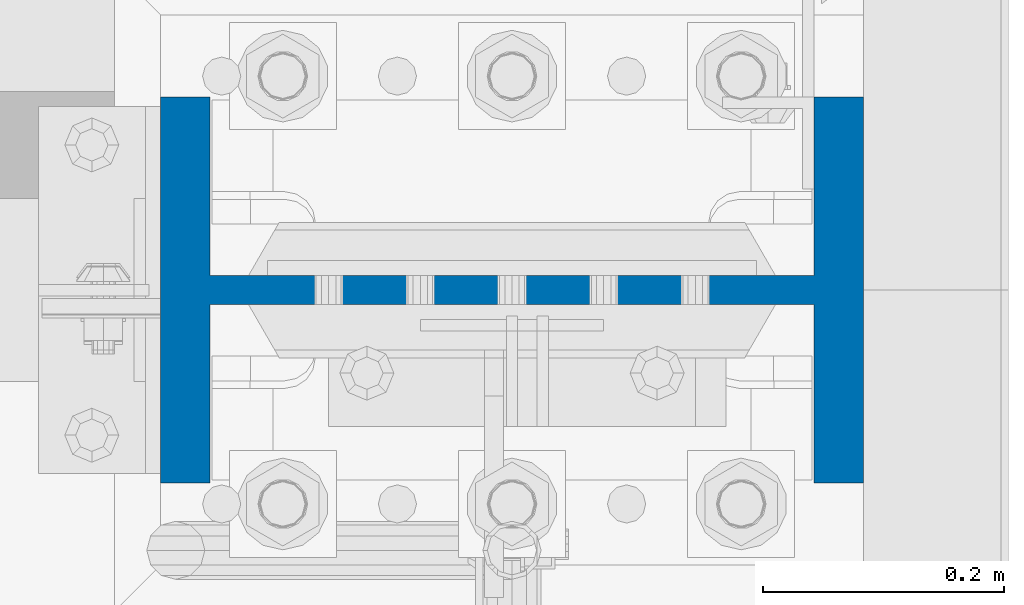
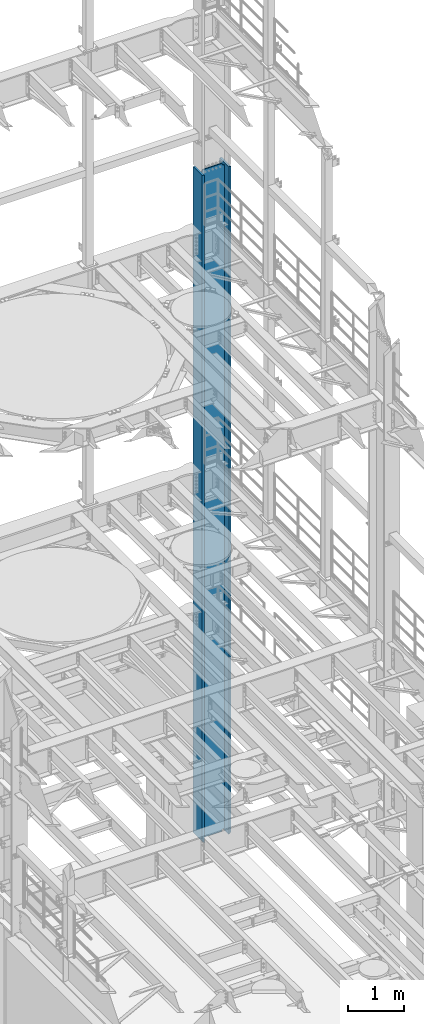
# One storey, part 775 of 1876: 1 column, 1 element without a shape of its own.
"""IFC2X3 building model written with IfcOpenShell, lengths in millimetres."""

import ifcopenshell
import ifcopenshell.guid

model = None  # the IFC model being written
_history = None  # IfcOwnerHistory: only IFC2X3 demands one
_inside = {}  # id of a spatial element -> (the spatial element, [elements in it])
_under = {}  # id of a project, library or spatial element -> (it, [spatial elements below it])
_declared = {}  # id of a project -> (the project, [libraries it declares])
_typed = {}  # id of a type object -> (the type object, [elements of that type])
_made_of = {}  # id of a material, layer set ... -> (it, [elements and type objects made of it])


def new_model(schema):
    """Start an empty IFC model of exactly this schema.

    Asked for "IFC4X3", IfcOpenShell would pick the latest addendum, in which some entities
    have other attributes; the version numbers below select the first issue.
    IFC2X3 requires an IfcOwnerHistory on every rooted entity: one is made here for all.
    """
    global model, _history
    if schema == "IFC4X3":
        model = ifcopenshell.file(schema_version=(4, 3, 0, 0))
    else:
        model = ifcopenshell.file(schema=schema)
    _inside.clear()
    _under.clear()
    _declared.clear()
    _typed.clear()
    _made_of.clear()
    _history = None
    if model.schema == "IFC2X3":
        org = make("IfcOrganization", Name="unknown")
        user = make(
            "IfcPersonAndOrganization",
            ThePerson=make("IfcPerson", FamilyName="unknown"),
            TheOrganization=org,
        )
        app = make(
            "IfcApplication",
            ApplicationDeveloper=org,
            Version="unknown",
            ApplicationFullName="unknown",
            ApplicationIdentifier="unknown",
        )
        _history = make(
            "IfcOwnerHistory",
            OwningUser=user,
            OwningApplication=app,
            ChangeAction="ADDED",
            CreationDate=0,
        )
    return model


def make(cls, **values):
    """One entity of the class cls with the attributes given. An attribute that is None is left unset."""
    return model.create_entity(
        cls, **{name: value for name, value in values.items() if value is not None}
    )


def rooted(cls, **values):
    """An entity with a GlobalId (a new one), such as an element, a storey or a relation."""
    return make(cls, GlobalId=ifcopenshell.guid.new(), OwnerHistory=_history, **values)


def si_unit(unit_type, name, prefix=None):
    """IfcSIUnit, for example si_unit("LENGTHUNIT", "METRE", prefix="MILLI")."""
    return make("IfcSIUnit", UnitType=unit_type, Prefix=prefix, Name=name)


def assignment(units):
    """IfcUnitAssignment: the units of a project."""
    return None if units is None else make("IfcUnitAssignment", Units=units)


def point(xyz):
    """IfcCartesianPoint."""
    return None if xyz is None else make("IfcCartesianPoint", Coordinates=xyz)


def direction(xyz):
    """IfcDirection."""
    return None if xyz is None else make("IfcDirection", DirectionRatios=xyz)


def frame(location, z_axis=None, x_axis=None):
    """IfcAxis2Placement3D, a coordinate frame: its origin and axes. An axis left out is left unset."""
    return make(
        "IfcAxis2Placement3D",
        Location=point(location),
        Axis=direction(z_axis),
        RefDirection=direction(x_axis),
    )


def origin_with_axes():
    """The frame at (0, 0, 0) with the z axis (0, 0, 1) and the x axis (1, 0, 0) written out."""
    return frame((0.0, 0.0, 0.0), z_axis=(0.0, 0.0, 1.0), x_axis=(1.0, 0.0, 0.0))


def place(relative_to, where):
    """IfcLocalPlacement: puts the frame where relative to a parent placement (None: the world)."""
    return make(
        "IfcLocalPlacement", PlacementRelTo=relative_to, RelativePlacement=where
    )


def context(
    kind, dimensions, precision=None, world=None, true_north=None, identifier=None
):
    """IfcGeometricRepresentationContext, for example the 3D "Model" context."""
    return make(
        "IfcGeometricRepresentationContext",
        ContextIdentifier=identifier,
        ContextType=kind,
        CoordinateSpaceDimension=dimensions,
        Precision=precision,
        WorldCoordinateSystem=world,
        TrueNorth=true_north,
    )


def subcontext(parent, identifier, kind, view, scale=None):
    """IfcGeometricRepresentationSubContext, for example "Body" below "Model"."""
    return make(
        "IfcGeometricRepresentationSubContext",
        ContextIdentifier=identifier,
        ContextType=kind,
        ParentContext=parent,
        TargetScale=scale,
        TargetView=view,
    )


def project(units=None, contexts=None):
    """IfcProject with its units and contexts."""
    return rooted(
        "IfcProject",
        Name="project",
        RepresentationContexts=contexts,
        UnitsInContext=assignment(units),
    )


def spatial(cls, under=None, at=None, **own):
    """A site, building, storey or space (cls), placed at a placement, below another one or the project."""
    s = rooted(cls, ObjectPlacement=at, **own)
    if under is not None:
        _under.setdefault(under.id(), (under, []))[1].append(s)
    return s


def faces_of(points, faces, orient=None, outer=None):
    """IfcFace entities. A face is a list of loops; a loop is a list of indices into points, from 0.

    orient and outer hold one flag for each loop. By default every Orientation is true, the
    first loop of a face is its IfcFaceOuterBound and the others are IfcFaceBound.
    """
    made = []
    for i, loops in enumerate(faces):
        bounds = []
        for j, loop in enumerate(loops):
            is_outer = j == 0 if outer is None else outer[i][j]
            bounds.append(
                make(
                    "IfcFaceOuterBound" if is_outer else "IfcFaceBound",
                    Bound=make("IfcPolyLoop", Polygon=[points[k] for k in loop]),
                    Orientation=True if orient is None else orient[i][j],
                )
            )
        made.append(make("IfcFace", Bounds=bounds))
    return made


def faceted_brep(points, faces, orient=None, outer=None, voids=None):
    """IfcFacetedBrep: a solid bounded by flat faces; with voids (closed shells), ...WithVoids."""
    shared = [point(p) for p in points]
    hull = make("IfcClosedShell", CfsFaces=faces_of(shared, faces, orient, outer))
    if voids is None:
        return make("IfcFacetedBrep", Outer=hull)
    return make(
        "IfcFacetedBrepWithVoids",
        Outer=hull,
        Voids=[
            make(cls, CfsFaces=faces_of(shared, fs, o, b)) for cls, fs, o, b in voids
        ],
    )


def shape(context_of_items, identifier, shape_type, items):
    """IfcShapeRepresentation: the items that make up one representation, for example the "Body"."""
    return make(
        "IfcShapeRepresentation",
        ContextOfItems=context_of_items,
        RepresentationIdentifier=identifier,
        RepresentationType=shape_type,
        Items=items,
    )


def material(Name=None, Category=None):
    """IfcMaterial."""
    return make("IfcMaterial", Name=Name, Category=Category)


def made_of(thing, what):
    """Note that an element or type object is made of a material, layer set ...; save() writes the relation."""
    if what is not None:
        _made_of.setdefault(what.id(), (what, []))[1].append(thing)
    return thing


def type_object(cls, material=None, **own):
    """A type object (cls), such as IfcWallType, which elements share."""
    return made_of(rooted(cls, **own), material)


def element(
    cls,
    number,
    at=None,
    inside=None,
    cuts=None,
    type_object=None,
    material=None,
    context=None,
    identifier="Body",
    shape_type=None,
    held_by="IfcProductDefinitionShape",
    body=None,
    shapes=None,
    **own,
):
    """One element of the class cls, such as IfcWall. Its Tag is "e" and its number.

    at: its placement. inside: the storey or other place that contains it. cuts: it is an
    opening in that element (IfcRelVoidsElement). A single representation is given by context,
    identifier, shape_type and body (its items); several are given by shapes. held_by: the class
    of the entity that holds the representations. save() writes the other relations.
    """
    e = rooted(cls, Tag="e%d" % number, ObjectPlacement=at, **own)
    if body is not None:
        shapes = [shape(context, identifier, shape_type, body)]
    if shapes is not None:
        e.Representation = make(held_by, Representations=shapes)
    if inside is not None:
        _inside.setdefault(inside.id(), (inside, []))[1].append(e)
    if cuts is not None:
        rooted(
            "IfcRelVoidsElement", RelatingBuildingElement=cuts, RelatedOpeningElement=e
        )
    if type_object is not None:
        _typed.setdefault(type_object.id(), (type_object, []))[1].append(e)
    return made_of(e, material)


def aggregate(whole, parts):
    """IfcRelAggregates: a whole, such as a stair, and the parts it consists of."""
    return rooted("IfcRelAggregates", RelatingObject=whole, RelatedObjects=parts)


def save(model, path):
    """Write the relations noted so far, then the file.

    IfcRelAggregates (storeys below a building ...), IfcRelContainedInSpatialStructure (elements
    in a storey), IfcRelDefinesByType, IfcRelAssociatesMaterial and IfcRelDeclares: one each for
    every whole, place, type object, material and project.
    """
    for whole, parts in _under.values():
        aggregate(whole, parts)
    for where, things in _inside.values():
        rooted(
            "IfcRelContainedInSpatialStructure",
            RelatedElements=things,
            RelatingStructure=where,
        )
    for kind, things in _typed.values():
        rooted("IfcRelDefinesByType", RelatedObjects=things, RelatingType=kind)
    for what, things in _made_of.values():
        rooted("IfcRelAssociatesMaterial", RelatedObjects=things, RelatingMaterial=what)
    for by, libraries in _declared.values():
        rooted("IfcRelDeclares", RelatingContext=by, RelatedDefinitions=libraries)
    model.write(path)


model = new_model("IFC2X3")

# Units and contexts
model_context = context("Model", 3, precision=1e-05, world=origin_with_axes())
body_context = subcontext(model_context, "Body", "Model", "MODEL_VIEW")
ifc_project = project(units=[si_unit("LENGTHUNIT", "METRE", prefix="MILLI"), si_unit("AREAUNIT", "SQUARE_METRE"), si_unit("VOLUMEUNIT", "CUBIC_METRE"), si_unit("MASSUNIT", "GRAM", prefix="KILO"), si_unit("TIMEUNIT", "SECOND"), si_unit("PLANEANGLEUNIT", "RADIAN"), si_unit("SOLIDANGLEUNIT", "STERADIAN"), si_unit("THERMODYNAMICTEMPERATUREUNIT", "DEGREE_CELSIUS"), si_unit("LUMINOUSINTENSITYUNIT", "LUMEN")], contexts=[model_context])

# Site, building, storey
site_placement = place(None, origin_with_axes())
site = spatial("IfcSite", under=ifc_project, at=site_placement, CompositionType="ELEMENT")
building_placement = place(site_placement, origin_with_axes())
building = spatial("IfcBuilding", under=site, at=building_placement, Name="Undefined", CompositionType="ELEMENT")
storey_placement = place(building_placement, origin_with_axes())
storey = spatial("IfcBuildingStorey", under=building, at=storey_placement, Name="Undefined", CompositionType="ELEMENT", Elevation=0.0)

# Assembly, column
assembly_placement = place(storey_placement, origin_with_axes())
assembly = element("IfcElementAssembly", 1, at=assembly_placement, inside=storey, Name="COLUMN", AssemblyPlace="NOTDEFINED", PredefinedType="RIGID_FRAME")
ifc_material = material(Name="STEEL/A992")
column_type = type_object("IfcColumnType", Name="W21X201", PredefinedType="NOTDEFINED")
column_placement = place(assembly_placement, frame((7620.0, 13716.0, 0.0), z_axis=(-1.0, 0.0, 0.0), x_axis=(0.0, 0.0, 1.0)))
column = element("IfcColumn", 2, at=column_placement, type_object=column_type, material=ifc_material, Name="COLUMN", ObjectType="W21X201", context=body_context, shape_type="Brep", body=[
    faceted_brep([(112.712499999999, 11.90625, 200.025000762939), (112.712499999999, 11.90625, -200.025000762939), (88.9, -11.90625, -200.025000762939), (88.9, -11.90625, 200.025000762939), (14528.8, -160.3375, 292.1), (14528.8, 160.3375, 292.1), (130.174999999997, 160.3375, 292.1), (130.175, -160.3375, 292.099999999999), (139.700000000013, -160.3375, 250.825), (14478.0, -160.3375, 250.825), (14528.8, -160.3375, 250.825), (88.9, -160.3375, 250.825), (139.700000000013, -11.90625, 250.825), (14478.0, -11.90625, 250.825), (14528.8, -11.90625, 250.825), (88.9, -11.90625, 250.825), (14528.8, -160.3375, -292.1), (14528.8, -160.3375, -250.825), (14478.0000007629, -160.3375, -250.825), (139.700000000013, -160.3375, -250.825), (88.9, -160.3375, -250.825), (130.175000825646, -160.3375, -292.100000825653), (14528.8, 160.3375, -292.1), (130.175000825646, 160.3375, -292.1), (139.700000000013, 160.3375, -250.825), (14478.0000007629, 160.3375, -250.825), (14528.8, 160.3375, -250.825), (88.9, 160.3375, -250.825), (14528.8, 11.90625, -250.825), (14528.8, -11.90625, -250.825), (14478.0000007629, -11.90625, -250.825), (139.700000000013, -11.90625, -250.825), (88.9, -11.90625, -250.825), (114.300000381483, -11.90625, -200.025000762939), (114.300000381483, 11.90625, -200.025000762939), (124.020159417574, 11.90625, -201.958460608115), (124.020159417574, -11.90625, -201.958460608115), (132.260512353882, 11.90625, -207.464488409071), (132.260512353882, -11.90625, -207.464488409071), (137.766540154838, 11.90625, -215.704841345379), (137.766540154838, -11.90625, -215.704841345379), (139.700000000013, 11.90625, -225.42500038147), (139.700000000013, -11.90625, -225.42500038147), (139.700000000013, 11.90625, -250.825), (88.9, 11.90625, -250.825), (14478.0000007629, 11.90625, -250.825), (14481.8669204533, 11.90625, -231.384681927819), (14481.8669204533, -11.90625, -231.384681927819), (14492.8789760552, 11.90625, -214.903976055204), (14492.8789760552, -11.90625, -214.903976055204), (14509.3596819278, 11.90625, -203.891920453291), (14509.3596819278, -11.90625, -203.891920453291), (14528.8, -11.90625, -200.02500076294), (14528.8, 11.90625, -200.02500076294), (14528.8, 11.90625, 200.02500076294), (14528.8, -11.90625, 200.02500076294), (14509.3596811649, 11.90625, 203.891920453291), (14509.3596811649, -11.90625, 203.891920453291), (14492.8789752923, 11.90625, 214.903976055204), (14492.8789752923, -11.90625, 214.903976055204), (14481.8669196904, 11.90625, 231.384681927819), (14481.8669196904, -11.90625, 231.384681927819), (14478.0, 11.90625, 250.825), (14528.8, 11.90625, 250.825), (14528.8, 160.3375, 250.825), (14478.0, 160.3375, 250.825), (139.700000000013, 160.3375, 250.825), (88.9, 160.3375, 250.825), (88.9, 11.90625, 250.825), (139.700000000013, 11.90625, 250.825), (139.700000000013, 11.90625, 225.42500038147), (139.700000000013, -11.90625, 225.42500038147), (137.766540154838, 11.90625, 215.704841345379), (137.766540154838, -11.90625, 215.704841345379), (132.260512353882, 11.90625, 207.464488409071), (132.260512353882, -11.90625, 207.464488409071), (124.020159417574, 11.90625, 201.958460608115), (124.020159417574, -11.90625, 201.958460608115), (114.300000381483, 11.90625, 200.025000762939), (114.300000381483, -11.90625, 200.025000762939)], [[[0, 1, 2, 3]], [[4, 5, 6, 7]], [[8, 9, 10, 4, 7, 11]], [[12, 13, 14, 10, 9, 8, 11, 15]], [[16, 17, 18, 19, 20, 21]], [[22, 16, 21, 23]], [[24, 25, 26, 22, 23, 27]], [[17, 16, 22, 26, 28, 29]], [[19, 18, 17, 29, 30, 31, 32, 20]], [[33, 34, 35, 36]], [[36, 35, 37, 38]], [[38, 37, 39, 40]], [[40, 39, 41, 42]], [[42, 41, 43, 31]], [[31, 43, 44, 32]], [[27, 23, 21, 20, 32, 44]], [[43, 45, 28, 26, 25, 24, 27, 44]], [[29, 28, 45, 30]], [[30, 45, 46, 47]], [[47, 46, 48, 49]], [[49, 48, 50, 51]], [[52, 51, 50, 53]], [[54, 55, 52, 53]], [[55, 54, 56, 57]], [[57, 56, 58, 59]], [[59, 58, 60, 61]], [[61, 60, 62, 13]], [[14, 13, 62, 63]], [[64, 5, 4, 10, 14, 63]], [[5, 64, 65, 66, 67, 6]], [[11, 7, 6, 67, 68, 15]], [[66, 65, 64, 63, 62, 69, 68, 67]], [[15, 68, 69, 12]], [[12, 69, 70, 71]], [[71, 70, 72, 73]], [[73, 72, 74, 75]], [[75, 74, 76, 77]], [[77, 76, 78, 79]], [[79, 78, 0, 3]], [[33, 36, 38, 40, 42, 31, 30, 47, 49, 51, 52, 55, 57, 59, 61, 13, 12, 71, 73, 75, 77, 79, 3, 2]], [[34, 33, 2, 1]], [[78, 76, 74, 72, 70, 69, 62, 60, 58, 56, 54, 53, 50, 48, 46, 45, 43, 41, 39, 37, 35, 34, 1, 0]]]),
])
aggregate(assembly, [column])

save(model, "model.ifc")
